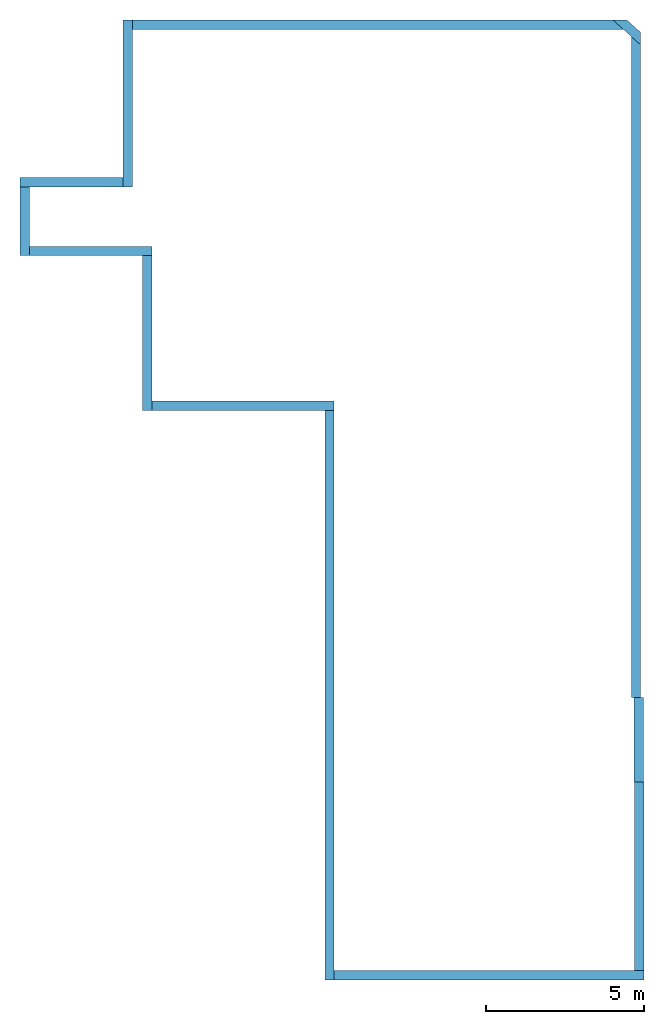
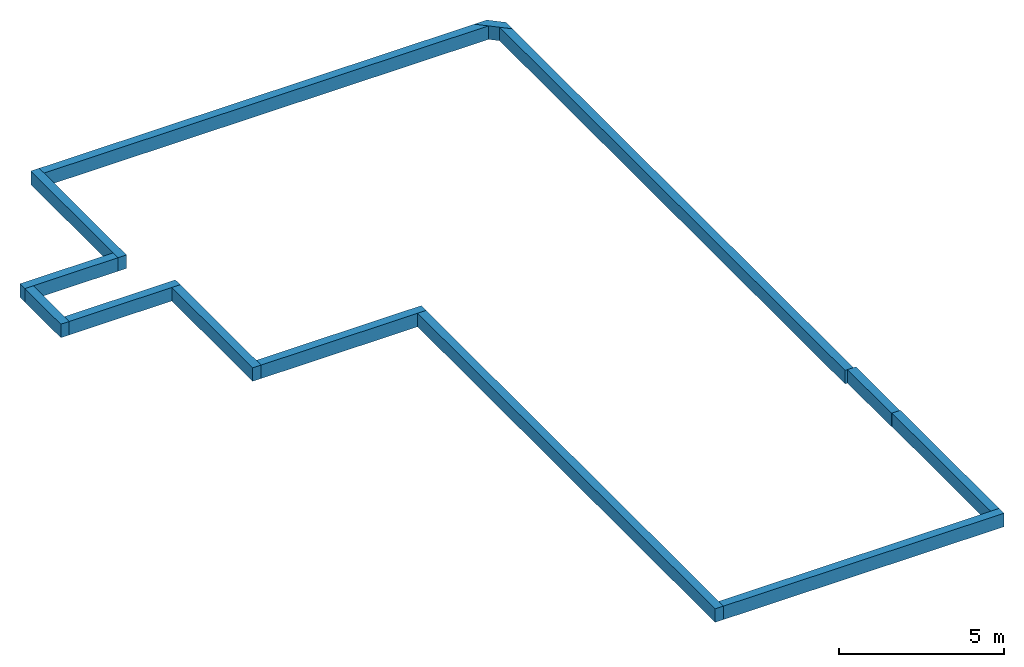
# One storey: 13 walls, 4 openings.
"""IFC2X3 building model written with IfcOpenShell, lengths in millimetres."""

from ifc_helpers import new_model, entity, si_unit, converted_unit, derived_unit, direction, frame, frame_2d, origin, place, context, subcontext, project, spatial, polyline, rectangle, outline, extrude, material, layer, layer_set, layer_usage, type_object, element, save


model = new_model("IFC2X3")

# Units and contexts
model_context = context("Model", 3, precision=0.01, world=origin(), true_north=direction((6.12303176911189e-17, 1.0)))
context_of_model = context(None, 3, precision=0.01, world=origin(), true_north=direction((6.12303176911189e-17, 1.0)))
body_context = subcontext(model_context, "Body", "Model", "MODEL_VIEW")
ifc_project = project(units=[si_unit("LENGTHUNIT", "METRE", prefix="MILLI"), si_unit("AREAUNIT", "SQUARE_METRE"), si_unit("VOLUMEUNIT", "CUBIC_METRE"), converted_unit("PLANEANGLEUNIT", "DEGREE", entity("IfcRatioMeasure", 0.0174532925199433), si_unit("PLANEANGLEUNIT", "RADIAN"), dimensions=[0, 0, 0, 0, 0, 0, 0]), si_unit("MASSUNIT", "GRAM", prefix="KILO"), si_unit("TIMEUNIT", "SECOND"), si_unit("FREQUENCYUNIT", "HERTZ"), si_unit("THERMODYNAMICTEMPERATUREUNIT", "DEGREE_CELSIUS"), derived_unit("THERMALTRANSMITTANCEUNIT", [(si_unit("MASSUNIT", "GRAM", prefix="KILO"), 1), (si_unit("THERMODYNAMICTEMPERATUREUNIT", "KELVIN"), -1), (si_unit("TIMEUNIT", "SECOND"), -3)]), derived_unit("VOLUMETRICFLOWRATEUNIT", [(si_unit("LENGTHUNIT", "METRE"), 3), (si_unit("TIMEUNIT", "SECOND"), -1)]), si_unit("ELECTRICCURRENTUNIT", "AMPERE"), si_unit("ELECTRICVOLTAGEUNIT", "VOLT"), si_unit("POWERUNIT", "WATT"), si_unit("FORCEUNIT", "NEWTON", prefix="KILO"), si_unit("ILLUMINANCEUNIT", "LUX"), si_unit("LUMINOUSFLUXUNIT", "LUMEN"), si_unit("LUMINOUSINTENSITYUNIT", "CANDELA"), si_unit("PRESSUREUNIT", "PASCAL")], contexts=[model_context, context_of_model])

# Site, building, storey
site_placement = place(None, origin())
site = spatial("IfcSite", under=ifc_project, at=site_placement, CompositionType="ELEMENT")
building_placement = place(site_placement, origin())
building = spatial("IfcBuilding", under=site, at=building_placement, CompositionType="ELEMENT")
storey_placement = place(building_placement, frame((0.0, 0.0, -500.0)))
storey = spatial("IfcBuildingStorey", under=building, at=storey_placement, Name="Level 1", CompositionType="ELEMENT", Elevation=-500.000000000001)

# Wall
ifc_material = material(Name="Concrete, Cast In Situ")
ifc_layer = layer(ifc_material, 295.0)
ifc_layer_set = layer_set([ifc_layer], Name="Basic Wall:295 mm")
ifc_layer_usage_1 = layer_usage(ifc_layer_set, "AXIS2", "NEGATIVE", 147.5)
wall_type = type_object("IfcWallType", Name="Basic Wall:295 mm", PredefinedType="STANDARD", material=ifc_layer_set)
wall_1_placement = place(storey_placement, frame((-10865.4599628916, 14616.3951971478, 0.0), z_axis=(0.0, 0.0, 1.0), x_axis=(0.0, -1.0, 0.0)))
element("IfcWallStandardCase", 1, at=wall_1_placement, inside=storey, type_object=wall_type, material=ifc_layer_usage_1, Name="Basic Wall:295 mm", ObjectType="Basic Wall:295 mm", context=body_context, shape_type="SweptSolid", body=[
    extrude(rectangle(XDim=5292.08645388702, YDim=294.999999999998, at=frame_2d((2646.04322694351, 5.25801624462474e-13), x_axis=(-1.0, 0.0))), origin(), (0.0, 0.0, 1.0), 500.0),
])

# Wall, opening
ifc_layer_usage_2 = layer_usage(ifc_layer_set, "AXIS2", "NEGATIVE", 147.5)
wall_2_placement = place(storey_placement, frame((-11012.9599628916, 9471.80874326079, 0.0), z_axis=(0.0, 0.0, 1.0), x_axis=(-1.0, 0.0, 0.0)))
wall_2 = element("IfcWallStandardCase", 2, at=wall_2_placement, inside=storey, type_object=wall_type, material=ifc_layer_usage_2, Name="Basic Wall:295 mm", ObjectType="Basic Wall:295 mm", context=body_context, shape_type="SweptSolid", body=[
    extrude(rectangle(XDim=3263.38219167418, YDim=295.0, at=frame_2d((1631.69109583709, 2.55795384873636e-13), x_axis=(-1.0, 0.0))), origin(), (0.0, 0.0, 1.0), 500.0),
])
opening_1_placement = place(wall_2_placement, origin())
element("IfcOpeningElement", 3, at=opening_1_placement, cuts=wall_2, Name="Basic Wall:295 mm", ObjectType="Opening", context=body_context, shape_type="SweptSolid", body=[
    extrude(rectangle(XDim=2134.0, YDim=812.999999999999, at=frame_2d((-1.10844666778576e-12, 0.0), x_axis=(0.0, 1.0))), frame((391.993832170185, -1399.0, 1567.0), z_axis=(0.0, 1.0, 0.0), x_axis=(-1.0, 0.0, 0.0)), (0.0, 0.0, 1.0), 3048.0),
])

ifc_layer_usage_3 = layer_usage(ifc_layer_set, "AXIS2", "NEGATIVE", 147.5)
wall_3_placement = place(storey_placement, frame((-14128.8421545658, 9324.3087432608, 0.0), z_axis=(0.0, 0.0, 1.0), x_axis=(0.0, -1.0, 0.0)))
wall_3 = element("IfcWallStandardCase", 4, at=wall_3_placement, inside=storey, type_object=wall_type, material=ifc_layer_usage_3, Name="Basic Wall:295 mm", ObjectType="Basic Wall:295 mm", context=body_context, shape_type="SweptSolid", body=[
    extrude(rectangle(XDim=2178.61841982792, YDim=294.999999999998, at=frame_2d((1089.30920991396, 1.4210854715202e-14), x_axis=(-1.0, 0.0))), origin(), (0.0, 0.0, 1.0), 500.0),
])
opening_2_placement = place(wall_3_placement, origin())
element("IfcOpeningElement", 5, at=opening_2_placement, cuts=wall_3, Name="Basic Wall:295 mm", ObjectType="Opening", context=body_context, shape_type="SweptSolid", body=[
    extrude(rectangle(XDim=2032.0, YDim=864.0, at=frame_2d((-5.40012479177676e-13, 0.0), x_axis=(0.0, 1.0))), frame((949.500000000004, -1423.11780832582, 1516.0), z_axis=(0.0, 1.0, 0.0), x_axis=(-1.0, 0.0, 0.0)), (0.0, 0.0, 1.0), 3048.0),
])

ifc_layer_usage_4 = layer_usage(ifc_layer_set, "AXIS2", "NEGATIVE", 147.5)
wall_4_placement = place(storey_placement, frame((-13981.3421545658, 7293.19032343288, 0.0)))
wall_4 = element("IfcWallStandardCase", 6, at=wall_4_placement, inside=storey, type_object=wall_type, material=ifc_layer_usage_4, Name="Basic Wall:295 mm", ObjectType="Basic Wall:295 mm", context=body_context, shape_type="SweptSolid", body=[
    extrude(rectangle(XDim=3888.11735936512, YDim=295.0, at=frame_2d((1944.05867968256, 4.2632564145606e-14), x_axis=(-1.0, 0.0))), origin(), (0.0, 0.0, 1.0), 500.0),
])
opening_3_placement = place(wall_4_placement, origin())
element("IfcOpeningElement", 7, at=opening_3_placement, cuts=wall_4, Name="Basic Wall:295 mm", ObjectType="Opening", context=body_context, shape_type="SweptSolid", body=[
    extrude(rectangle(XDim=2134.0, YDim=812.999999999999, at=frame_2d((-1.10844666778576e-12, 0.0), x_axis=(0.0, 1.0))), frame((1425.48387712817, -1419.55475189727, 1567.0), z_axis=(0.0, 1.0, 0.0), x_axis=(-1.0, 0.0, 0.0)), (0.0, 0.0, 1.0), 3048.0),
])

# Walls
ifc_layer_usage_5 = layer_usage(ifc_layer_set, "AXIS2", "NEGATIVE", 147.5)
wall_5_placement = place(storey_placement, frame((-10240.7247952007, 7145.69032343287, 0.0), z_axis=(0.0, 0.0, 1.0), x_axis=(0.0, -1.0, 0.0)))
element("IfcWallStandardCase", 8, at=wall_5_placement, inside=storey, type_object=wall_type, material=ifc_layer_usage_5, Name="Basic Wall:295 mm", ObjectType="Basic Wall:295 mm", context=body_context, shape_type="SweptSolid", body=[
    extrude(rectangle(XDim=4908.78661944904, YDim=294.999999999998, at=frame_2d((2454.39330972452, 1.27897692436818e-13), x_axis=(-1.0, 0.0))), origin(), (0.0, 0.0, 1.0), 500.0),
])
ifc_layer_usage_6 = layer_usage(ifc_layer_set, "AXIS2", "NEGATIVE", 147.5)
wall_6_placement = place(storey_placement, frame((-10093.2247952007, 2384.40370398383, 0.0)))
element("IfcWallStandardCase", 9, at=wall_6_placement, inside=storey, type_object=wall_type, material=ifc_layer_usage_6, Name="Basic Wall:295 mm", ObjectType="Basic Wall:295 mm", context=body_context, shape_type="SweptSolid", body=[
    extrude(rectangle(XDim=5775.0, YDim=295.0, at=frame_2d((2887.5, 0.0), x_axis=(-1.0, 0.0))), origin(), (0.0, 0.0, 1.0), 500.0),
])

# Wall, opening
ifc_layer_usage_7 = layer_usage(ifc_layer_set, "AXIS2", "NEGATIVE", 147.5)
wall_7_placement = place(storey_placement, frame((-4465.72479520071, 2236.90370398381, 0.0), z_axis=(0.0, 0.0, 1.0), x_axis=(0.0, -1.0, 0.0)))
wall_7 = element("IfcWallStandardCase", 10, at=wall_7_placement, inside=storey, type_object=wall_type, material=ifc_layer_usage_7, Name="Basic Wall:295 mm", ObjectType="Basic Wall:295 mm", context=body_context, shape_type="SweptSolid", body=[
    extrude(rectangle(XDim=18052.3119283711, YDim=295.0, at=frame_2d((9026.15596418557, 1.4210854715202e-14), x_axis=(-1.0, 0.0))), origin(), (0.0, 0.0, 1.0), 500.0),
])
opening_4_placement = place(wall_7_placement, origin())
element("IfcOpeningElement", 11, at=opening_4_placement, cuts=wall_7, Name="Basic Wall:295 mm", ObjectType="Opening", context=body_context, shape_type="SweptSolid", body=[
    extrude(rectangle(XDim=2500.0, YDim=1190.0, at=frame_2d((2.27373675443232e-13, 0.0), x_axis=(1.0, 0.0))), frame((10426.0939852418, -1169.86329757784, 1750.0), z_axis=(0.0, 1.0, 0.0), x_axis=(0.0, 0.0, 1.0)), (0.0, 0.0, 1.0), 3048.0),
])

# Walls
ifc_layer_usage_8 = layer_usage(ifc_layer_set, "AXIS2", "NEGATIVE", 147.5)
wall_8_placement = place(storey_placement, frame((-4318.22479520074, -15667.9082243873, 0.0)))
element("IfcWallStandardCase", 12, at=wall_8_placement, inside=storey, type_object=wall_type, material=ifc_layer_usage_8, Name="Basic Wall:295 mm", ObjectType="Basic Wall:295 mm", context=body_context, shape_type="SweptSolid", body=[
    extrude(rectangle(XDim=9821.06173455107, YDim=294.999999999998, at=frame_2d((4910.53086727554, -9.9475983006414e-14), x_axis=(-1.0, 0.0))), origin(), (0.0, 0.0, 1.0), 500.0),
])
ifc_layer_usage_9 = layer_usage(ifc_layer_set, "AXIS2", "NEGATIVE", 147.5)
wall_9_placement = place(storey_placement, frame((5355.33693935033, -15520.4082243874, 0.0), z_axis=(0.0, 0.0, 1.0), x_axis=(0.0, 1.0, 0.0)))
element("IfcWallStandardCase", 13, at=wall_9_placement, inside=storey, type_object=wall_type, material=ifc_layer_usage_9, Name="Basic Wall:295 mm", ObjectType="Basic Wall:295 mm", context=body_context, shape_type="SweptSolid", body=[
    extrude(rectangle(XDim=5988.71794312934, YDim=295.0, at=frame_2d((2994.35897156467, 1.84741111297626e-13), x_axis=(-1.0, 0.0))), origin(), (0.0, 0.0, 1.0), 500.0),
])
ifc_layer_usage_10 = layer_usage(ifc_layer_set, "AXIS2", "NEGATIVE", 147.5)
wall_10_placement = place(storey_placement, frame((5336.70880946343, -9531.69028125802, 0.0), z_axis=(0.0, 0.0, 1.0), x_axis=(0.0, 1.0, 0.0)))
element("IfcWallStandardCase", 14, at=wall_10_placement, inside=storey, type_object=wall_type, material=ifc_layer_usage_10, Name="Basic Wall:295 mm", ObjectType="Basic Wall:295 mm", context=body_context, shape_type="SweptSolid", body=[
    extrude(rectangle(XDim=2668.5939852418, YDim=295.0, at=frame_2d((1334.2969926209, -1.4210854715202e-14), x_axis=(-1.0, 0.0))), origin(), (0.0, 0.0, 1.0), 500.0),
])
ifc_layer_usage_11 = layer_usage(ifc_layer_set, "AXIS2", "NEGATIVE", 147.5)
wall_11_placement = place(storey_placement, frame((5250.33693935035, -6863.09629601623, 0.0), z_axis=(0.0, 0.0, 1.0), x_axis=(0.0, 1.0, 0.0)))
element("IfcWallStandardCase", 15, at=wall_11_placement, inside=storey, type_object=wall_type, material=ifc_layer_usage_11, Name="Basic Wall:295 mm", ObjectType="Basic Wall:295 mm", context=body_context, shape_type="SweptSolid", body=[
    extrude(outline(polyline([(20689.5683587934, -147.5), (20955.1875518613, 147.5), (0.0, 147.5), (0.0, 61.1281298869138), (0.0, -147.5), (20689.5683587934, -147.5)])), origin(), (0.0, 0.0, 1.0), 500.0),
])
ifc_layer_usage_12 = layer_usage(ifc_layer_set, "AXIS2", "NEGATIVE", 147.5)
wall_12_placement = place(storey_placement, frame((5496.53370378831, 13936.0859245351, 0.0), z_axis=(0.0, 0.0, 1.0), x_axis=(-0.743144825477393, 0.66913060635886, 0.0)))
element("IfcWallStandardCase", 16, at=wall_12_placement, inside=storey, type_object=wall_type, material=ifc_layer_usage_12, Name="Basic Wall:295 mm", ObjectType="Basic Wall:295 mm", context=body_context, shape_type="SweptSolid", body=[
    extrude(outline(polyline([(852.890908637742, -147.500000000002), (1180.52160051235, 147.499999999999), (739.651018302298, 147.499999999998), (396.961655233881, 147.499999999999), (0.0, 147.5), (265.619193067865, -147.500000000002), (852.890908637742, -147.500000000002)])), origin(), (0.0, 0.0, 1.0), 500.0),
])
ifc_layer_usage_13 = layer_usage(ifc_layer_set, "AXIS2", "NEGATIVE", 147.5)
wall_13_placement = place(storey_placement, frame((4848.16911243994, 14468.8951971478, 0.0), z_axis=(0.0, 0.0, 1.0), x_axis=(-1.0, 0.0, 0.0)))
element("IfcWallStandardCase", 17, at=wall_13_placement, inside=storey, type_object=wall_type, material=ifc_layer_usage_13, Name="Basic Wall:295 mm", ObjectType="Basic Wall:295 mm", context=body_context, shape_type="SweptSolid", body=[
    extrude(outline(polyline([(15566.1290753316, -147.5), (15566.1290753316, 147.5), (0.0, 147.499999999999), (327.630691874613, -147.5), (15566.1290753316, -147.5)])), origin(), (0.0, 0.0, 1.0), 500.0),
])

save(model, "model.ifc")
